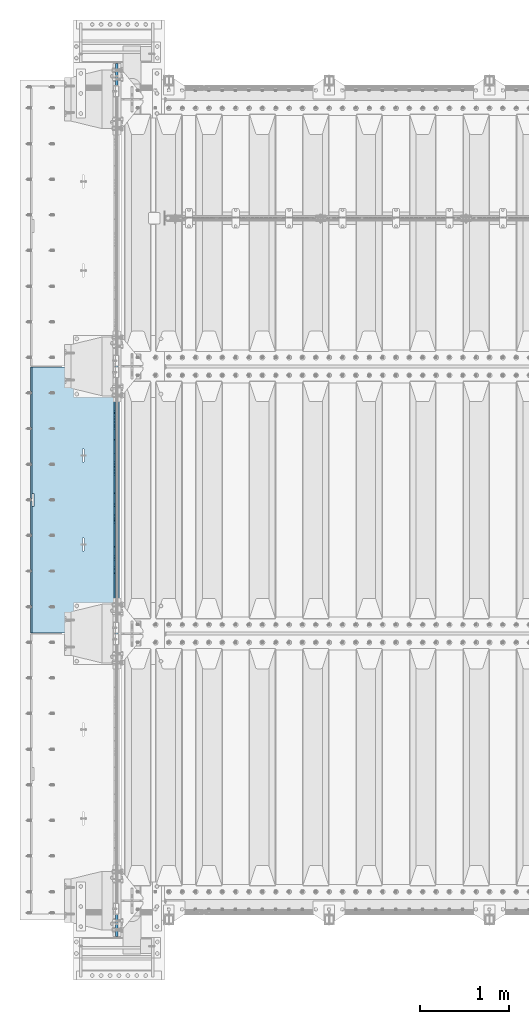
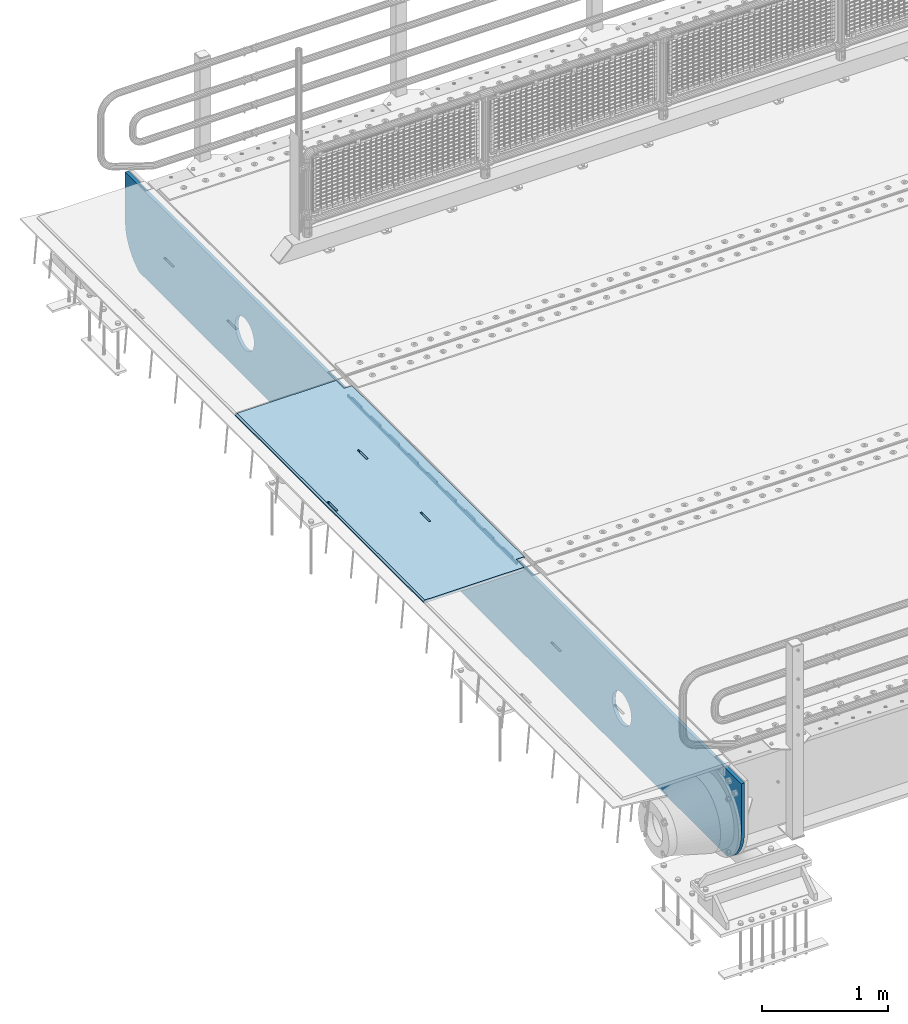
# One storey, part 210 of 270: 3 plates.
"""IFC2X3 building model written with IfcOpenShell, lengths in millimetres."""

from ifc_helpers import new_model, si_unit, frame, origin_with_axes, place, context, subcontext, project, spatial, faceted_brep, material, type_object, element, save


model = new_model("IFC2X3")

# Units and contexts
model_context = context("Model", 3, precision=1e-05, world=origin_with_axes())
body_context = subcontext(model_context, "Body", "Model", "MODEL_VIEW")
ifc_project = project(units=[si_unit("LENGTHUNIT", "METRE", prefix="MILLI"), si_unit("AREAUNIT", "SQUARE_METRE"), si_unit("VOLUMEUNIT", "CUBIC_METRE"), si_unit("MASSUNIT", "GRAM", prefix="KILO"), si_unit("TIMEUNIT", "SECOND"), si_unit("PLANEANGLEUNIT", "RADIAN"), si_unit("SOLIDANGLEUNIT", "STERADIAN"), si_unit("THERMODYNAMICTEMPERATUREUNIT", "DEGREE_CELSIUS"), si_unit("LUMINOUSINTENSITYUNIT", "LUMEN")], contexts=[model_context])

# Site, building, storey
site_placement = place(None, origin_with_axes())
site = spatial("IfcSite", under=ifc_project, at=site_placement, CompositionType="ELEMENT")
building_placement = place(site_placement, origin_with_axes())
building = spatial("IfcBuilding", under=site, at=building_placement, Name="Standard", CompositionType="ELEMENT")
storey_placement = place(building_placement, origin_with_axes())
storey = spatial("IfcBuildingStorey", under=building, at=storey_placement, Name="Undefined", CompositionType="ELEMENT", Elevation=0.0)

# Plates
ifc_material = material(Name="STEEL/S355N")
plate_type_1 = type_object("IfcPlateType", PredefinedType="NOTDEFINED")
plate_1_placement = place(storey_placement, frame((-57.5, -18154.9999005917, -36.0014545213866), z_axis=(0.0, -0.999999999987744, -4.95099999993769e-06), x_axis=(0.0, 4.95100000930963e-06, -0.999999999987744)))
element("IfcPlate", 1, at=plate_1_placement, inside=storey, type_object=plate_type_1, material=ifc_material, context=body_context, shape_type="Brep", body=[
    faceted_brep([(-7.105427357601e-15, -7.49999999999999, 0.0), (-1.24856569527765e-10, -7.5, 70.0000000000036), (-1.24856569527765e-10, 7.5, 70.0000000000036), (-7.105427357601e-15, 7.5, 0.0), (-14.9899997711175, -7.5, 70.0000000000036), (-14.9899997711175, 7.5, 70.0000000000036), (-14.9899997711161, -7.5, 220.0), (-14.9899997711161, 7.5, 220.0), (-3.90834031804843e-10, -7.5, 220.000000000004), (-3.90834031804843e-10, 7.5, 220.000000000004), (-6.56825704936637e-10, -7.5, 370.0), (-6.56825704936637e-10, 7.5, 370.0), (-14.9899997711147, -7.5, 370.000000000004), (-14.9899997711147, 7.5, 370.000000000004), (-14.9899997711133, -7.5, 520.000000000004), (-14.9899997711133, 7.5, 520.000000000004), (-9.24629262044618e-10, -7.5, 520.000000000004), (-9.24629262044618e-10, 7.5, 520.000000000004), (-1.1906067243217e-09, -7.5, 670.000000000004), (-1.1906067243217e-09, 7.5, 670.000000000004), (-14.9899997711119, -7.5, 670.0), (-14.9899997711119, 7.5, 670.0), (-14.9899997711105, -7.5, 820.000000000004), (-14.9899997711105, 7.5, 820.000000000004), (-1.45477940804994e-09, -7.5, 820.0), (-1.45477940804994e-09, 7.5, 820.0), (-1.72257585973057e-09, -7.5, 970.000000000004), (-1.72257585973057e-09, 7.5, 970.000000000004), (-14.9899997711091, -7.5, 970.000000000004), (-14.9899997711091, 7.5, 970.000000000004), (-14.9899997711077, -7.5, 1120.0), (-14.9899997711077, 7.5, 1120.0), (-1.98856753286236e-09, -7.5, 1120.0), (-1.98856753286236e-09, 7.5, 1120.0), (-2.2545521005668e-09, -7.5, 1270.0), (-2.2545521005668e-09, 7.5, 1270.0), (-14.9899997711063, -7.5, 1270.0), (-14.9899997711063, 7.5, 1270.0), (-14.9899997711049, -7.5, 1420.0), (-14.9899997711049, 7.5, 1420.0), (-2.52235565767478e-09, -7.5, 1420.0), (-2.52235565767478e-09, 7.5, 1420.0), (-2.78834733080657e-09, -7.5, 1570.0), (-2.78834733080657e-09, 7.5, 1570.0), (-14.9899997711034, -7.5, 1570.0), (-14.9899997711034, 7.5, 1570.0), (-14.989999771102, -7.5, 1720.0), (-14.989999771102, 7.5, 1720.0), (-3.05433189851101e-09, -7.5, 1720.0), (-3.05433189851101e-09, 7.5, 1720.0), (-3.32212835019163e-09, -7.5, 1870.0), (-3.32212835019163e-09, 7.5, 1870.0), (-14.9899997711006, -7.5, 1870.0), (-14.9899997711006, 7.5, 1870.0), (-14.9899997710992, -7.5, 2020.0), (-14.9899997710992, 7.5, 2020.0), (-3.58812002332343e-09, -7.5, 2020.0), (-3.58812002332343e-09, 7.5, 2020.0), (-3.85410459102786e-09, -7.5, 2170.0), (-3.85410459102786e-09, 7.5, 2170.0), (-14.9899997710978, -7.5, 2170.0), (-14.9899997710978, 7.5, 2170.0), (-14.9899997710964, -7.5, 2320.0), (-14.9899997710964, 7.5, 2320.0), (-4.12190814813584e-09, -7.5, 2320.0), (-4.12190814813584e-09, 7.5, 2320.0), (-4.38789271584028e-09, -7.5, 2470.0), (-4.38789271584028e-09, 7.5, 2470.0), (-14.9999999999768, -7.5, 2470.0), (-14.9999999999768, 7.5, 2470.0), (-14.9899997710936, -7.5, 2620.0), (-14.9899997710936, 7.5, 2620.0), (-4.65388438897207e-09, -7.5, 2620.0), (-4.65388438897207e-09, 7.5, 2620.0), (-4.77873385307248e-09, -7.5, 2690.0), (-4.77873385307248e-09, 7.5, 2690.0), (25.0100002289071, -7.5, 2690.0), (25.0100002289071, 7.5, 2690.0), (25.0, -7.49999999999999, 0.0), (25.0, 7.5, 0.0)], [[[0, 1, 2, 3]], [[1, 4, 5, 2]], [[4, 6, 7, 5]], [[6, 8, 9, 7]], [[8, 10, 11, 9]], [[10, 12, 13, 11]], [[12, 14, 15, 13]], [[14, 16, 17, 15]], [[16, 18, 19, 17]], [[18, 20, 21, 19]], [[20, 22, 23, 21]], [[22, 24, 25, 23]], [[24, 26, 27, 25]], [[26, 28, 29, 27]], [[28, 30, 31, 29]], [[30, 32, 33, 31]], [[32, 34, 35, 33]], [[34, 36, 37, 35]], [[36, 38, 39, 37]], [[38, 40, 41, 39]], [[40, 42, 43, 41]], [[42, 44, 45, 43]], [[44, 46, 47, 45]], [[46, 48, 49, 47]], [[48, 50, 51, 49]], [[50, 52, 53, 51]], [[52, 54, 55, 53]], [[54, 56, 57, 55]], [[56, 58, 59, 57]], [[58, 60, 61, 59]], [[60, 62, 63, 61]], [[62, 64, 65, 63]], [[64, 66, 67, 65]], [[66, 68, 69, 67]], [[68, 70, 71, 69]], [[70, 72, 73, 71]], [[72, 74, 75, 73]], [[74, 76, 77, 75]], [[76, 78, 79, 77]], [[78, 0, 3, 79]], [[5, 7, 9, 11, 13, 15, 17, 19, 21, 23, 25, 27, 29, 31, 33, 35, 37, 39, 41, 43, 45, 47, 49, 51, 53, 55, 57, 59, 61, 63, 65, 67, 69, 71, 73, 75, 77, 79, 3, 2]], [[78, 76, 74, 72, 70, 68, 66, 64, 62, 60, 58, 56, 54, 52, 50, 48, 46, 44, 42, 40, 38, 36, 34, 32, 30, 28, 26, 24, 22, 20, 18, 16, 14, 12, 10, 8, 6, 4, 1, 0]]]),
])
plate_type_2 = type_object("IfcPlateType", PredefinedType="NOTDEFINED")
plate_2_placement = place(storey_placement, frame((-5.00375433032989, -18005.0000738272, -1.00001208605641), z_axis=(0.0, -0.999999999987744, -4.95099999993769e-06), x_axis=(-0.999999999879068, -1.00000022172504e-09, -1.55519999981193e-05)))
element("IfcPlate", 2, at=plate_2_placement, inside=storey, type_object=plate_type_2, material=ifc_material, context=body_context, shape_type="Brep", body=[
    faceted_brep([(-0.000111589569153914, -5.71507077553601e-05, 2865.00000504125), (15.0002388791539, 15.0, 2865.00008049103), (15.000010422308, 15.0, 125.000079348152), (-0.000225737458036335, 5.71560140520955e-05, 125.000003632551), (999.996459960937, 5.0, 3.63797880709171e-12), (984.996459960937, 15.0, 3.63797880709171e-12), (984.996459730713, 15.0, 2990.0), (999.996459730713, 4.99999999999999, 2990.00000000001), (999.996459730713, -5.0, 2990.00000000001), (984.99645973052, -15.0, 2990.0), (984.996459961366, -15.0, 0.0), (999.996459960937, -5.0, 3.63797880709171e-12), (959.999522276416, -15.0000000031848, 1560.00000000851), (959.999522276416, 15.0, 1560.00000000851), (960.488957113226, 15.0, 1563.09016995226), (960.488957113226, -15.0000000031888, 1563.09016995227), (961.909352332213, 15.0, 1565.87785253144), (961.909352332213, -15.0000000032008, 1565.87785253144), (964.121669752867, 15.0, 1568.09016995226), (964.121669752867, -15.0000000032196, 1568.09016995227), (966.909352331933, 15.0, 1569.51056517147), (966.909352331933, -15.0000000032433, 1569.51056517147), (969.999522275633, 15.0, 1570.00000000851), (969.999522275633, -15.0000000032698, 1570.00000000852), (973.089692219423, 15.0, 1569.51056517146), (973.089692219423, -15.0000000032962, 1569.51056517147), (975.877374798709, 15.0, 1568.09016995226), (975.877374798709, -15.0000000033202, 1568.09016995226), (978.089692219705, 15.0, 1565.87785253143), (978.089692219705, -15.0000000033393, 1565.87785253143), (979.51008743912, 15.0, 1563.09016995225), (979.51008743912, -15.0000000033517, 1563.09016995225), (979.999522276404, 15.0, 1560.0000000085), (979.999522276404, -15.0000000033561, 1560.0000000085), (979.999522286274, 15.0, 1430.0000000085), (979.999522286274, -15.0000000033654, 1430.0000000085), (979.510087449461, 15.0, 1426.90983006476), (979.510087449461, -15.0000000033615, 1426.90983006476), (978.089692230473, 15.0, 1424.12214748558), (978.089692230472, -15.0000000033495, 1424.12214748558), (975.877374809819, 15.0, 1421.90983006476), (975.877374809819, -15.0000000033307, 1421.90983006476), (973.089692230754, 15.0, 1420.48943484556), (973.089692230754, -15.0000000033069, 1420.48943484556), (969.999522287207, 15.0, 1420.00000000851), (969.999522287207, -15.0000000032805, 1420.00000000851), (966.90935234342, 15.0, 1420.48943484556), (966.90935234342, -15.000000003254, 1420.48943484556), (964.121669764135, 15.0, 1421.90983006476), (964.121669764135, -15.00000000323, 1421.90983006477), (961.90935234314, 15.0, 1424.12214748558), (961.90935234314, -15.0000000032109, 1424.12214748559), (960.488957123723, 15.0, 1426.90983006476), (960.488957123723, -15.0000000031986, 1426.90983006476), (959.999522286436, 15.0, 1430.00000000851), (959.999522286436, -15.0000000031941, 1430.00000000851), (-0.000461899023639134, -14.9999999925605, 124.999928197263), (-0.000462055621302859, -14.9999999889596, 2864.99992960655), (75.0002624101966, 15.0, 125.000080471727), (74.9997898801964, -15.0, 124.99992960173), (74.9997820614451, -15.0, 0.0), (75.0002485914438, 15.0, 0.0), (75.0005015105598, 15.0, 2990.0), (75.0000289805597, -15.0, 2990.0), (75.000491135538, 15.0, 2865.00008054906), (75.0000186055379, -14.999999997918, 2864.99992967906), (395.488957121483, -15.0, 1926.90983006544), (395.488957121483, 15.0, 1926.90983006544), (394.999522284197, 15.0, 1930.00000000919), (394.999522284197, -15.0, 1930.0000000092), (396.9093523409, -15.0, 1924.12214748627), (396.9093523409, 15.0, 1924.12214748627), (399.121669761895, -15.0, 1921.90983006544), (399.121669761895, 15.0, 1921.90983006544), (401.90935234118, -15.0, 1920.48943484624), (401.90935234118, 15.0, 1920.48943484624), (404.999522284967, -15.0, 1920.00000000919), (404.999522284967, 15.0, 1920.00000000919), (408.089692228539, -15.0, 1920.48943484624), (408.089692228539, 15.0, 1920.48943484624), (410.877374807603, -15.0, 1921.90983006544), (410.877374807603, 15.0, 1921.90983006544), (413.089692228257, -15.0, 1924.12214748627), (413.089692228257, 15.0, 1924.12214748626), (414.510087447246, -15.0, 1926.90983006544), (414.510087447246, 15.0, 1926.90983006543), (414.999522284058, -15.0, 1930.00000000919), (414.999522284058, 15.0, 1930.00000000918), (414.999522274167, -15.0, 2060.00000000919), (414.999522274167, 15.0, 2060.00000000918), (414.510087436882, -15.0, 2063.09016995294), (414.510087436882, 15.0, 2063.09016995294), (413.089692217466, -15.0, 2065.87785253211), (413.089692217466, 15.0, 2065.87785253211), (410.877374796471, -15.0, 2068.09016995294), (410.877374796471, 15.0, 2068.09016995294), (408.089692217185, -15.0, 2069.51056517215), (408.089692217185, 15.0, 2069.51056517215), (404.999522273396, -15.0, 2070.00000000919), (404.999522273396, 15.0, 2070.00000000919), (401.909352329694, -15.0, 2069.51056517215), (401.909352329694, 15.0, 2069.51056517214), (399.121669750628, -15.0, 2068.09016995294), (399.121669750628, 15.0, 2068.09016995295), (396.909352329974, -15.0, 2065.87785253212), (396.909352329974, 15.0, 2065.87785253212), (395.488957110987, -15.0, 2063.09016995294), (395.488957110987, 15.0, 2063.09016995294), (394.999522274176, -15.0, 2060.0000000092), (394.999522274176, 15.0, 2060.00000000919), (395.48895718799, -15.0, 1063.09016995159), (396.909352406977, -15.0, 1065.87785253076), (399.121669827631, -15.0, 1068.09016995159), (401.909352406696, -15.0, 1069.51056517079), (404.999522350398, -15.0, 1070.00000000784), (408.089692294187, -15.0, 1069.5105651708), (410.877374873474, -15.0, 1068.09016995159), (413.08969229447, -15.0, 1065.87785253076), (414.510087513886, -15.0, 1063.09016995158), (414.99952235117, -15.0, 1060.00000000783), (414.999522361062, -15.0, 930.000000007836), (414.510087524249, -15.0, 926.909830064087), (413.089692305261, -15.0, 924.122147484915), (410.877374884607, -15.0, 921.909830064091), (408.089692305543, -15.0, 920.489434844894), (404.999522361971, -15.0, 920.00000000784), (401.909352418184, -15.0, 920.489434844894), (399.121669838899, -15.0, 921.909830064091), (396.909352417904, -15.0, 924.122147484915), (395.488957198487, -15.0, 926.909830064091), (394.9995223612, -15.0, 930.000000007847), (394.99952235118, -15.0, 1060.00000000784), (396.909352417904, 15.0, 924.122147484919), (395.488957198487, 15.0, 926.909830064091), (399.121669838899, 15.0, 921.909830064094), (401.909352418184, 15.0, 920.489434844891), (404.999522361971, 15.0, 920.000000007836), (408.089692305543, 15.0, 920.489434844891), (410.877374884607, 15.0, 921.909830064091), (413.089692305261, 15.0, 924.122147484912), (414.510087524249, 15.0, 926.909830064084), (414.999522361062, 15.0, 930.000000007833), (414.99952235117, 15.0, 1060.00000000783), (414.510087513886, 15.0, 1063.09016995158), (413.08969229447, 15.0, 1065.87785253076), (410.877374873474, 15.0, 1068.09016995159), (408.089692294187, 15.0, 1069.51056517079), (404.999522350398, 15.0, 1070.00000000784), (401.909352406696, 15.0, 1069.51056517079), (399.121669827631, 15.0, 1068.09016995159), (396.909352406977, 15.0, 1065.87785253076), (395.48895718799, 15.0, 1063.09016995159), (394.99952235118, 15.0, 1060.00000000784), (394.9995223612, 15.0, 930.000000007843)], [[[0, 1, 2, 3]], [[4, 5, 6, 7]], [[8, 9, 10, 11]], [[12, 13, 14, 15]], [[15, 14, 16, 17]], [[17, 16, 18, 19]], [[19, 18, 20, 21]], [[21, 20, 22, 23]], [[23, 22, 24, 25]], [[25, 24, 26, 27]], [[27, 26, 28, 29]], [[29, 28, 30, 31]], [[31, 30, 32, 33]], [[33, 32, 34, 35]], [[35, 34, 36, 37]], [[37, 36, 38, 39]], [[39, 38, 40, 41]], [[41, 40, 42, 43]], [[43, 42, 44, 45]], [[45, 44, 46, 47]], [[47, 46, 48, 49]], [[49, 48, 50, 51]], [[51, 50, 52, 53]], [[53, 52, 54, 55]], [[55, 54, 13, 12]], [[56, 57, 0, 3]], [[58, 59, 56, 3, 2]], [[60, 59, 58, 61]], [[11, 10, 60, 61, 5, 4]], [[8, 11, 4, 7]], [[62, 63, 9, 8, 7, 6]], [[63, 62, 64, 65]], [[57, 65, 64, 1, 0]], [[66, 67, 68, 69]], [[70, 71, 67, 66]], [[72, 73, 71, 70]], [[74, 75, 73, 72]], [[76, 77, 75, 74]], [[78, 79, 77, 76]], [[80, 81, 79, 78]], [[82, 83, 81, 80]], [[84, 85, 83, 82]], [[86, 87, 85, 84]], [[88, 89, 87, 86]], [[90, 91, 89, 88]], [[92, 93, 91, 90]], [[94, 95, 93, 92]], [[96, 97, 95, 94]], [[98, 99, 97, 96]], [[100, 101, 99, 98]], [[102, 103, 101, 100]], [[104, 105, 103, 102]], [[106, 107, 105, 104]], [[108, 109, 107, 106]], [[69, 68, 109, 108]], [[63, 65, 57, 56, 59, 60, 10, 9], [15, 17, 19, 21, 23, 25, 27, 29, 31, 33, 35, 37, 39, 41, 43, 45, 47, 49, 51, 53, 55, 12], [110, 111, 112, 113, 114, 115, 116, 117, 118, 119, 120, 121, 122, 123, 124, 125, 126, 127, 128, 129, 130, 131], [106, 104, 102, 100, 98, 96, 94, 92, 90, 88, 86, 84, 82, 80, 78, 76, 74, 72, 70, 66, 69, 108]], [[128, 132, 133, 129]], [[127, 134, 132, 128]], [[126, 135, 134, 127]], [[125, 136, 135, 126]], [[124, 137, 136, 125]], [[123, 138, 137, 124]], [[122, 139, 138, 123]], [[121, 140, 139, 122]], [[120, 141, 140, 121]], [[119, 142, 141, 120]], [[118, 143, 142, 119]], [[117, 144, 143, 118]], [[116, 145, 144, 117]], [[115, 146, 145, 116]], [[114, 147, 146, 115]], [[113, 148, 147, 114]], [[112, 149, 148, 113]], [[111, 150, 149, 112]], [[110, 151, 150, 111]], [[131, 152, 151, 110]], [[130, 153, 152, 131]], [[129, 133, 153, 130]], [[64, 62, 6, 5, 61, 58, 2, 1], [50, 48, 46, 44, 42, 40, 38, 36, 34, 32, 30, 28, 26, 24, 22, 20, 18, 16, 14, 13, 54, 52], [132, 134, 135, 136, 137, 138, 139, 140, 141, 142, 143, 144, 145, 146, 147, 148, 149, 150, 151, 152, 153, 133], [71, 73, 75, 77, 79, 81, 83, 85, 87, 89, 91, 93, 95, 97, 99, 101, 103, 105, 107, 109, 68, 67]]]),
])
plate_type_3 = type_object("IfcPlateType", PredefinedType="NOTDEFINED")
plate_3_placement = place(storey_placement, frame((-35.0, -24400.0, -36.0000011039577), z_axis=(0.0, 1.0, 0.0), x_axis=(0.0, 0.0, -1.0)))
element("IfcPlate", 3, at=plate_3_placement, inside=storey, type_object=plate_type_3, material=ifc_material, context=body_context, shape_type="Brep", body=[
    faceted_brep([(449.263564616164, -15.0, 2047.11778936561), (449.263564616164, 15.0, 2047.11778936561), (477.402531117293, 15.0, 2038.58192701299), (477.402531117293, -15.0, 2038.58192701299), (503.335551132301, 15.0, 2024.72043882608), (503.335551132301, -15.0, 2024.72043882608), (526.066033245416, 15.0, 2006.06601402229), (526.066033245416, -15.0, 2006.06601402229), (544.720457776433, 15.0, 1983.33553168533), (544.720457776433, -15.0, 1983.33553168533), (558.581945652146, 15.0, 1957.40251150398), (558.581945652146, -15.0, 1957.40251150398), (567.117807667104, 15.0, 1929.26354490042), (567.117807667104, -15.0, 1929.26354490042), (570.000015431038, 15.0, 1899.99999658071), (570.000015431038, -15.0, 1899.99999658071), (567.117807315941, 15.0, 1870.73644829558), (567.117807315941, -15.0, 1870.73644829558), (558.581944963316, 15.0, 1842.59748179446), (558.581944963316, -15.0, 1842.59748179446), (544.720456776406, 15.0, 1816.66446177944), (544.720456776406, -15.0, 1816.66446177944), (526.066031972624, 15.0, 1793.93397966633), (526.066031972624, -15.0, 1793.93397966633), (503.335549635655, 15.0, 1775.27955513532), (503.335549635655, -15.0, 1775.27955513532), (477.40252945431, 15.0, 1761.4180672596), (477.40252945431, -15.0, 1761.4180672596), (449.26356285075, 15.0, 1752.88220524464), (449.26356285075, -15.0, 1752.88220524464), (420.000014531038, 15.0, 1749.99999748071), (420.000014531038, -15.0, 1749.99999748071), (390.736466245912, 15.0, 1752.8822055958), (390.736466245912, -15.0, 1752.8822055958), (362.597499744783, 15.0, 1761.41806794843), (362.597499744783, -15.0, 1761.41806794843), (336.664479729775, 15.0, 1775.27955613534), (336.664479729775, -15.0, 1775.27955613534), (313.933997616659, 15.0, 1793.93398093912), (313.933997616659, -15.0, 1793.93398093912), (295.279573085643, 15.0, 1816.66446327609), (295.279573085643, -15.0, 1816.66446327609), (281.41808520993, 15.0, 1842.59748345744), (281.41808520993, -15.0, 1842.59748345744), (272.882223194972, 15.0, 1870.73645006099), (272.882223194972, -15.0, 1870.73645006099), (270.000015431038, 15.0, 1899.99999838071), (270.000015431038, -15.0, 1899.99999838071), (272.882223546134, 15.0, 1929.26354666584), (272.882223546134, -15.0, 1929.26354666584), (281.41808589876, 15.0, 1957.40251316696), (281.41808589876, -15.0, 1957.40251316696), (295.279574085669, 15.0, 1983.33553318197), (295.279574085669, -15.0, 1983.33553318197), (313.933998889452, 15.0, 2006.06601529508), (313.933998889452, -15.0, 2006.06601529508), (336.66448122642, 15.0, 2024.7204398261), (336.66448122642, -15.0, 2024.7204398261), (362.597501407766, 15.0, 2038.58192770182), (362.597501407766, -15.0, 2038.58192770182), (390.736468011325, 15.0, 2047.11778971678), (390.736468011325, -15.0, 2047.11778971678), (420.000016331038, 15.0, 2049.99999748071), (420.000016331038, -15.0, 2049.99999748071), (-1.00212931641863e-06, 15.0, 9800.0), (-1.00212931641863e-06, -15.0, 9800.0), (479.000057686094, -15.0, 9799.99999712676), (479.000057656083, 15.0, 9800.0), (0.0, -15.0, 0.0), (0.0, 15.0, 0.0), (478.999999999389, 15.0, 0.0), (478.999999999389, -15.0, 0.0), (527.214672102027, 15.0, 2.91645036031332), (527.214672102027, -15.0, 2.91645036031332), (574.726265714921, 15.0, 11.6232730291122), (574.726265714921, -15.0, 11.6232730291122), (620.841954816912, 15.0, 25.9935029253647), (620.841954816912, -15.0, 25.9935029253647), (664.889268817405, 15.0, 45.8175897382462), (664.889268817405, -15.0, 45.8175897382462), (706.22589869236, 15.0, 70.8064536420679), (706.22589869236, -15.0, 70.8064536420679), (744.249063296216, 15.0, 100.595700731094), (744.249063296216, -15.0, 100.595700731094), (778.404299268338, 15.0, 134.750936703214), (778.404299268338, -15.0, 134.750936703214), (808.19354635736, 15.0, 172.77410130707), (808.19354635736, -15.0, 172.77410130707), (833.182410261182, 15.0, 214.110731182027), (833.182410261182, -15.0, 214.110731182027), (838.999998585997, -15.0, 227.036882186476), (838.999998585997, 15.0, 227.036882186476), (838.999940378862, 15.0, 9572.96326607097), (838.999940378862, -15.0, 9572.96326613763), (833.18242576531, 15.0, 9585.88925446572), (833.18242579531, -15.0, 9585.88925446572), (808.193562534323, 15.0, 9627.22588611658), (808.193562564323, -15.0, 9627.22588611658), (778.404315787583, 15.0, 9665.24905247707), (778.404315817583, -15.0, 9665.24905247707), (744.249079843274, 15.0, 9699.40429013404), (744.249079873274, -15.0, 9699.40429013404), (706.225914976521, 15.0, 9729.1935387874), (706.225915006521, -15.0, 9729.1935387874), (664.889284578693, 15.0, 9754.18240409115), (664.889284608693, -15.0, 9754.18240409115), (620.841969832218, 15.0, 9774.00649210147), (620.841969862217, -15.0, 9774.00649210147), (574.726279803176, 15.0, 9788.37672296118), (574.726279833176, -15.0, 9788.37672296118), (527.214685128306, 15.0, 9797.08354633524), (527.214685158306, -15.0, 9797.08354633524), (390.736498873119, -15.0, 8047.11778971677), (390.736498873119, 15.0, 8047.11778971677), (420.000047192832, 15.0, 8049.99999748071), (420.000047192832, -15.0, 8049.99999748071), (362.59753226956, -15.0, 8038.58192770182), (362.59753226956, 15.0, 8038.58192770182), (336.664512088214, -15.0, 8024.7204398261), (336.664512088214, 15.0, 8024.7204398261), (313.934029751246, -15.0, 8006.06601529508), (313.934029751246, 15.0, 8006.06601529508), (295.279604947463, -15.0, 7983.33553318197), (295.279604947463, 15.0, 7983.33553318197), (281.418116760554, -15.0, 7957.40251316696), (281.418116760554, 15.0, 7957.40251316696), (272.882254407928, -15.0, 7929.26354666584), (272.882254407928, 15.0, 7929.26354666584), (270.000046292832, -15.0, 7899.99999838071), (270.000046292832, 15.0, 7899.99999838071), (272.882254056766, -15.0, 7870.73645006099), (272.882254056766, 15.0, 7870.73645006099), (281.418116071723, -15.0, 7842.59748345744), (281.418116071723, 15.0, 7842.59748345744), (295.279603947437, -15.0, 7816.66446327609), (295.279603947437, 15.0, 7816.66446327609), (313.934028478453, -15.0, 7793.93398093912), (313.934028478453, 15.0, 7793.93398093912), (336.664510591569, -15.0, 7775.27955613534), (336.664510591569, 15.0, 7775.27955613534), (362.597530606576, -15.0, 7761.41806794843), (362.597530606576, 15.0, 7761.41806794843), (390.736497107706, -15.0, 7752.8822055958), (390.736497107706, 15.0, 7752.8822055958), (420.000045392832, -15.0, 7749.99999748071), (420.000045392832, 15.0, 7749.99999748071), (449.263593712544, -15.0, 7752.88220524464), (449.263593712544, 15.0, 7752.88220524464), (477.402560316104, -15.0, 7761.4180672596), (477.402560316104, 15.0, 7761.4180672596), (503.335580497449, -15.0, 7775.27955513532), (503.335580497449, 15.0, 7775.27955513532), (526.066062834418, -15.0, 7793.93397966633), (526.066062834418, 15.0, 7793.93397966633), (544.7204876382, -15.0, 7816.66446177944), (544.7204876382, 15.0, 7816.66446177944), (558.58197582511, -15.0, 7842.59748179446), (558.58197582511, 15.0, 7842.59748179446), (567.117838177735, -15.0, 7870.73644829558), (567.117838177735, 15.0, 7870.73644829558), (570.000046292832, -15.0, 7899.99999658071), (570.000046292832, 15.0, 7899.99999658071), (567.117838528897, -15.0, 7929.26354490042), (567.117838528897, 15.0, 7929.26354490042), (558.58197651394, -15.0, 7957.40251150398), (558.58197651394, 15.0, 7957.40251150398), (544.720488638227, -15.0, 7983.33553168533), (544.720488638227, 15.0, 7983.33553168533), (526.06606410721, -15.0, 8006.06601402229), (526.06606410721, 15.0, 8006.06601402229), (503.335581994095, -15.0, 8024.72043882608), (503.335581994095, 15.0, 8024.72043882608), (477.402561979087, -15.0, 8038.58192701299), (477.402561979087, 15.0, 8038.58192701299), (449.263595477958, -15.0, 8047.11778936561), (449.263595477958, 15.0, 8047.11778936561), (477.402546541581, -15.0, 5038.58192701299), (503.335566556588, -15.0, 5024.72043882608), (526.066048669704, -15.0, 5006.06601402229), (544.72047320072, -15.0, 4983.33553168533), (558.581961076434, -15.0, 4957.40251150398), (567.117823091391, -15.0, 4929.26354490042), (570.000030855326, -15.0, 4899.99999658071), (567.117822740229, -15.0, 4870.73644829558), (558.581960387603, -15.0, 4842.59748179446), (544.720472200694, -15.0, 4816.66446177944), (526.066047396912, -15.0, 4793.93397966633), (503.335565059943, -15.0, 4775.27955513532), (477.402544878597, -15.0, 4761.4180672596), (449.263578275038, -15.0, 4752.88220524464), (420.000029955325, -15.0, 4749.99999748071), (390.7364816702, -15.0, 4752.8822055958), (362.59751516907, -15.0, 4761.41806794843), (336.664495154063, -15.0, 4775.27955613534), (313.934013040947, -15.0, 4793.93398093912), (295.27958850993, -15.0, 4816.66446327609), (281.418100634217, -15.0, 4842.59748345744), (272.88223861926, -15.0, 4870.73645006099), (270.000030855325, -15.0, 4899.99999838071), (272.882238970422, -15.0, 4929.26354666584), (281.418101323047, -15.0, 4957.40251316696), (295.279589509957, -15.0, 4983.33553318197), (313.934014313739, -15.0, 5006.06601529508), (336.664496650708, -15.0, 5024.7204398261), (362.597516832054, -15.0, 5038.58192770182), (390.736483435613, -15.0, 5047.11778971678), (420.000031755325, -15.0, 5049.99999748071), (449.263580040452, -15.0, 5047.11778936561), (362.597516832054, 15.0, 5038.58192770182), (390.736483435613, 15.0, 5047.11778971678), (336.664496650708, 15.0, 5024.7204398261), (313.934014313739, 15.0, 5006.06601529508), (295.279589509957, 15.0, 4983.33553318197), (281.418101323047, 15.0, 4957.40251316696), (272.882238970422, 15.0, 4929.26354666584), (270.000030855325, 15.0, 4899.99999838071), (272.88223861926, 15.0, 4870.73645006099), (281.418100634217, 15.0, 4842.59748345744), (295.27958850993, 15.0, 4816.66446327609), (313.934013040947, 15.0, 4793.93398093912), (336.664495154063, 15.0, 4775.27955613534), (362.59751516907, 15.0, 4761.41806794843), (390.7364816702, 15.0, 4752.8822055958), (420.000029955325, 15.0, 4749.99999748071), (449.263578275038, 15.0, 4752.88220524464), (477.402544878597, 15.0, 4761.4180672596), (503.335565059943, 15.0, 4775.27955513532), (526.066047396912, 15.0, 4793.93397966633), (544.720472200694, 15.0, 4816.66446177944), (558.581960387603, 15.0, 4842.59748179446), (567.117822740229, 15.0, 4870.73644829558), (570.000030855326, 15.0, 4899.99999658071), (567.117823091391, 15.0, 4929.26354490042), (558.581961076434, 15.0, 4957.40251150398), (544.72047320072, 15.0, 4983.33553168533), (526.066048669704, 15.0, 5006.06601402229), (503.335566556588, 15.0, 5024.72043882608), (477.402546541581, 15.0, 5038.58192701299), (449.263580040452, 15.0, 5047.11778936561), (420.000031755325, 15.0, 5049.99999748071)], [[[0, 1, 2, 3]], [[3, 2, 4, 5]], [[5, 4, 6, 7]], [[7, 6, 8, 9]], [[9, 8, 10, 11]], [[11, 10, 12, 13]], [[13, 12, 14, 15]], [[15, 14, 16, 17]], [[17, 16, 18, 19]], [[19, 18, 20, 21]], [[21, 20, 22, 23]], [[23, 22, 24, 25]], [[25, 24, 26, 27]], [[27, 26, 28, 29]], [[29, 28, 30, 31]], [[31, 30, 32, 33]], [[33, 32, 34, 35]], [[35, 34, 36, 37]], [[37, 36, 38, 39]], [[39, 38, 40, 41]], [[41, 40, 42, 43]], [[43, 42, 44, 45]], [[45, 44, 46, 47]], [[47, 46, 48, 49]], [[49, 48, 50, 51]], [[51, 50, 52, 53]], [[53, 52, 54, 55]], [[55, 54, 56, 57]], [[57, 56, 58, 59]], [[59, 58, 60, 61]], [[61, 60, 62, 63]], [[63, 62, 1, 0]], [[64, 65, 66, 67]], [[68, 65, 64, 69]], [[68, 69, 70, 71]], [[71, 70, 72, 73]], [[73, 72, 74, 75]], [[75, 74, 76, 77]], [[77, 76, 78, 79]], [[79, 78, 80, 81]], [[81, 80, 82, 83]], [[83, 82, 84, 85]], [[85, 84, 86, 87]], [[87, 86, 88, 89]], [[90, 89, 88, 91]], [[90, 91, 92, 93]], [[93, 92, 94, 95]], [[95, 94, 96, 97]], [[97, 96, 98, 99]], [[99, 98, 100, 101]], [[101, 100, 102, 103]], [[103, 102, 104, 105]], [[105, 104, 106, 107]], [[107, 106, 108, 109]], [[109, 108, 110, 111]], [[66, 111, 110, 67]], [[112, 113, 114, 115]], [[116, 117, 113, 112]], [[118, 119, 117, 116]], [[120, 121, 119, 118]], [[122, 123, 121, 120]], [[124, 125, 123, 122]], [[126, 127, 125, 124]], [[128, 129, 127, 126]], [[130, 131, 129, 128]], [[132, 133, 131, 130]], [[134, 135, 133, 132]], [[136, 137, 135, 134]], [[138, 139, 137, 136]], [[140, 141, 139, 138]], [[142, 143, 141, 140]], [[144, 145, 143, 142]], [[146, 147, 145, 144]], [[148, 149, 147, 146]], [[150, 151, 149, 148]], [[152, 153, 151, 150]], [[154, 155, 153, 152]], [[156, 157, 155, 154]], [[158, 159, 157, 156]], [[160, 161, 159, 158]], [[162, 163, 161, 160]], [[164, 165, 163, 162]], [[166, 167, 165, 164]], [[168, 169, 167, 166]], [[170, 171, 169, 168]], [[172, 173, 171, 170]], [[174, 175, 173, 172]], [[115, 114, 175, 174]], [[65, 68, 71, 73, 75, 77, 79, 81, 83, 85, 87, 89, 90, 93, 95, 97, 99, 101, 103, 105, 107, 109, 111, 66], [3, 5, 7, 9, 11, 13, 15, 17, 19, 21, 23, 25, 27, 29, 31, 33, 35, 37, 39, 41, 43, 45, 47, 49, 51, 53, 55, 57, 59, 61, 63, 0], [176, 177, 178, 179, 180, 181, 182, 183, 184, 185, 186, 187, 188, 189, 190, 191, 192, 193, 194, 195, 196, 197, 198, 199, 200, 201, 202, 203, 204, 205, 206, 207], [172, 170, 168, 166, 164, 162, 160, 158, 156, 154, 152, 150, 148, 146, 144, 142, 140, 138, 136, 134, 132, 130, 128, 126, 124, 122, 120, 118, 116, 112, 115, 174]], [[204, 208, 209, 205]], [[203, 210, 208, 204]], [[202, 211, 210, 203]], [[201, 212, 211, 202]], [[200, 213, 212, 201]], [[199, 214, 213, 200]], [[198, 215, 214, 199]], [[197, 216, 215, 198]], [[196, 217, 216, 197]], [[195, 218, 217, 196]], [[194, 219, 218, 195]], [[193, 220, 219, 194]], [[192, 221, 220, 193]], [[191, 222, 221, 192]], [[190, 223, 222, 191]], [[189, 224, 223, 190]], [[188, 225, 224, 189]], [[187, 226, 225, 188]], [[186, 227, 226, 187]], [[185, 228, 227, 186]], [[184, 229, 228, 185]], [[183, 230, 229, 184]], [[182, 231, 230, 183]], [[181, 232, 231, 182]], [[180, 233, 232, 181]], [[179, 234, 233, 180]], [[178, 235, 234, 179]], [[177, 236, 235, 178]], [[176, 237, 236, 177]], [[207, 238, 237, 176]], [[206, 239, 238, 207]], [[205, 209, 239, 206]], [[108, 106, 104, 102, 100, 98, 96, 94, 92, 91, 88, 86, 84, 82, 80, 78, 76, 74, 72, 70, 69, 64, 67, 110], [58, 56, 54, 52, 50, 48, 46, 44, 42, 40, 38, 36, 34, 32, 30, 28, 26, 24, 22, 20, 18, 16, 14, 12, 10, 8, 6, 4, 2, 1, 62, 60], [208, 210, 211, 212, 213, 214, 215, 216, 217, 218, 219, 220, 221, 222, 223, 224, 225, 226, 227, 228, 229, 230, 231, 232, 233, 234, 235, 236, 237, 238, 239, 209], [117, 119, 121, 123, 125, 127, 129, 131, 133, 135, 137, 139, 141, 143, 145, 147, 149, 151, 153, 155, 157, 159, 161, 163, 165, 167, 169, 171, 173, 175, 114, 113]]]),
])

save(model, "model.ifc")
